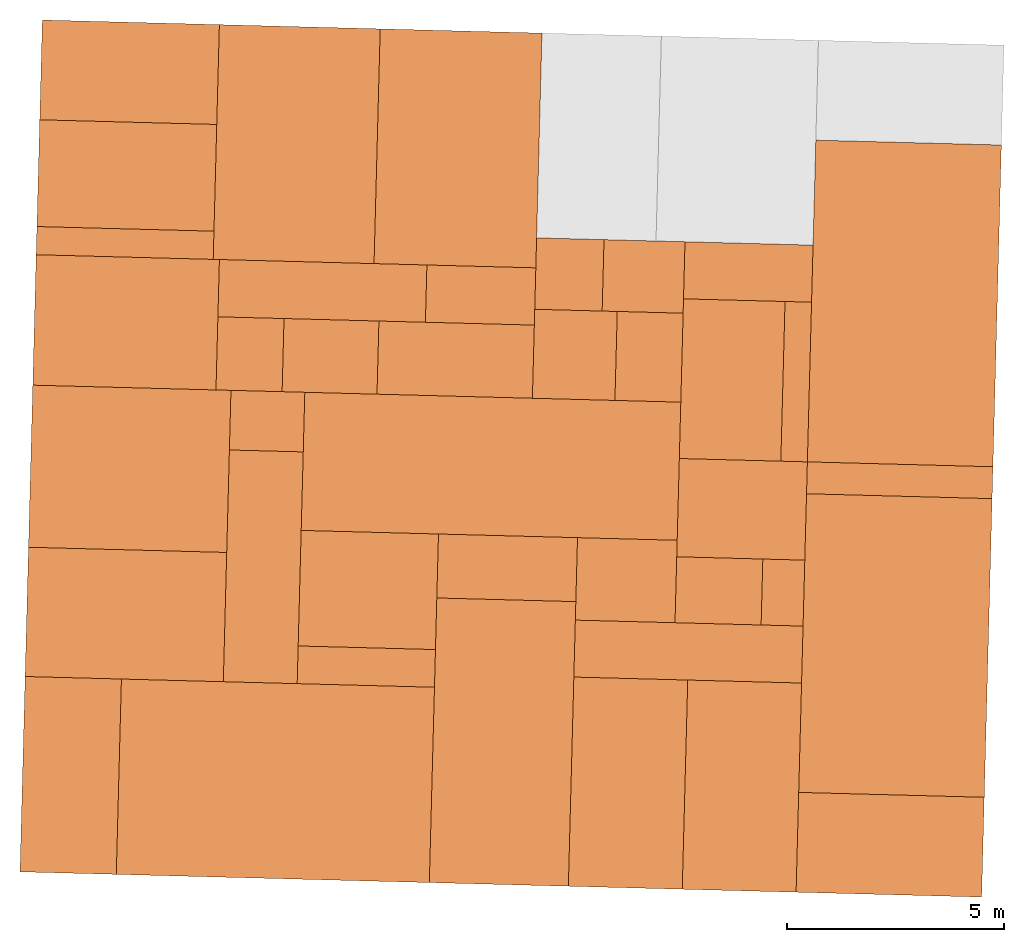
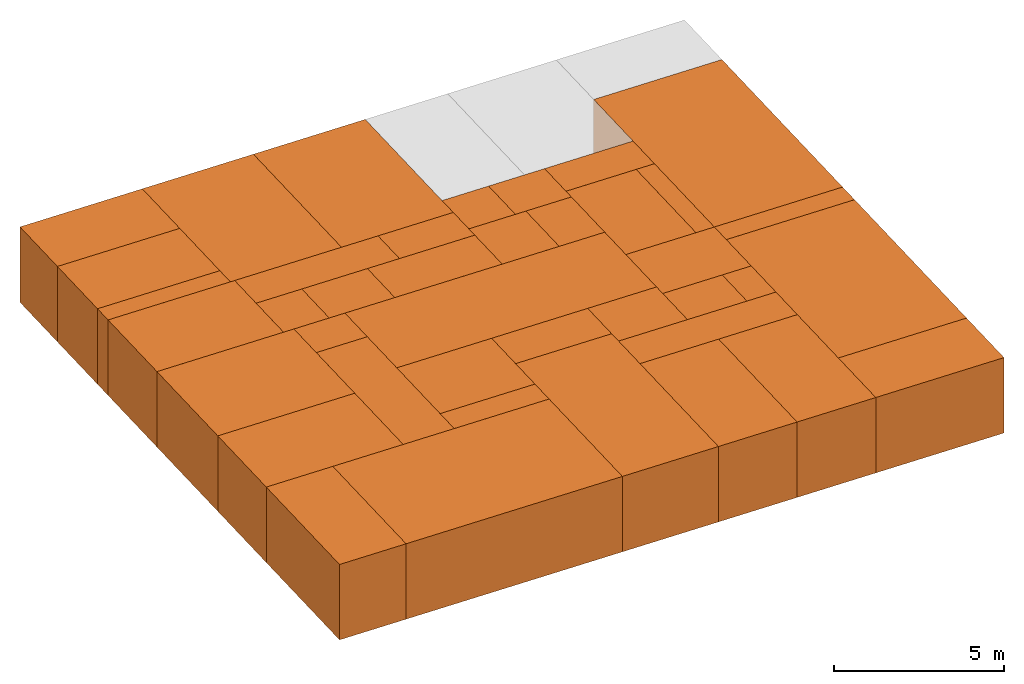
# One storey, part 1 of 2: 40 proxies.
"""IFC2X3 building model written with IfcOpenShell, lengths in metres."""

from ifc_helpers import new_model, entity, si_unit, converted_unit, derived_unit, direction, frame, frame_2d, origin, origin_2d_with_axis, place, context, subcontext, project, spatial, rectangle, extrude, source, transform, mapped, material, type_object, type_shapes, element, save


model = new_model("IFC2X3")

# Units and contexts
model_context = context("Model", 3, precision=1e-05, world=origin(), true_north=direction((-0.999656054706472, -0.0262254130318397)))
body_context = subcontext(model_context, "Body", "Model", "MODEL_VIEW")
ifc_project = project(units=[si_unit("LENGTHUNIT", "METRE"), si_unit("AREAUNIT", "SQUARE_METRE"), si_unit("VOLUMEUNIT", "CUBIC_METRE"), converted_unit("PLANEANGLEUNIT", "DEGREE", entity("IfcRatioMeasure", 0.0174532925199433), si_unit("PLANEANGLEUNIT", "RADIAN"), dimensions=[0, 0, 0, 0, 0, 0, 0]), si_unit("MASSUNIT", "GRAM", prefix="KILO"), derived_unit("MASSDENSITYUNIT", [(si_unit("MASSUNIT", "GRAM", prefix="KILO"), 1), (si_unit("LENGTHUNIT", "METRE"), -3)]), si_unit("TIMEUNIT", "SECOND"), si_unit("FREQUENCYUNIT", "HERTZ"), si_unit("THERMODYNAMICTEMPERATUREUNIT", "DEGREE_CELSIUS"), derived_unit("THERMALTRANSMITTANCEUNIT", [(si_unit("MASSUNIT", "GRAM", prefix="KILO"), 1), (si_unit("THERMODYNAMICTEMPERATUREUNIT", "KELVIN"), -1), (si_unit("TIMEUNIT", "SECOND"), -3)]), derived_unit("VOLUMETRICFLOWRATEUNIT", [(si_unit("LENGTHUNIT", "METRE"), 3), (si_unit("TIMEUNIT", "SECOND"), -1)]), si_unit("ELECTRICCURRENTUNIT", "AMPERE"), si_unit("ELECTRICVOLTAGEUNIT", "VOLT"), si_unit("POWERUNIT", "WATT"), si_unit("FORCEUNIT", "NEWTON", prefix="KILO"), si_unit("ILLUMINANCEUNIT", "LUX"), si_unit("LUMINOUSFLUXUNIT", "LUMEN"), si_unit("LUMINOUSINTENSITYUNIT", "CANDELA"), derived_unit("USERDEFINED", [(si_unit("MASSUNIT", "GRAM", prefix="KILO"), -1), (si_unit("LENGTHUNIT", "METRE"), -2), (si_unit("TIMEUNIT", "SECOND"), 3), (si_unit("LUMINOUSFLUXUNIT", "LUMEN"), 1)]), derived_unit("LINEARVELOCITYUNIT", [(si_unit("LENGTHUNIT", "METRE"), 1), (si_unit("TIMEUNIT", "SECOND"), -1)]), si_unit("PRESSUREUNIT", "PASCAL"), derived_unit("USERDEFINED", [(si_unit("LENGTHUNIT", "METRE"), -2), (si_unit("MASSUNIT", "GRAM", prefix="KILO"), 1), (si_unit("TIMEUNIT", "SECOND"), -2)])], contexts=[model_context])

# Site, building, storey
site_placement = place(None, frame((0.0, 0.0, 0.0), z_axis=(0.0, 0.0, 1.0), x_axis=(-0.0262254130318394, -0.999656054706472, 0.0)))
site = spatial("IfcSite", under=ifc_project, at=site_placement, CompositionType="ELEMENT")
building_placement = place(site_placement, origin())
building = spatial("IfcBuilding", under=site, at=building_placement, CompositionType="ELEMENT")
storey_placement = place(building_placement, frame((0.0, 0.0, 2.7)))
storey = spatial("IfcBuildingStorey", under=building, at=storey_placement, Name="1OG", CompositionType="ELEMENT", Elevation=2.7)

# Proxies
ifc_material_1 = material(Name="010_DiningRoom")
building_element_proxy_type_1 = type_object("IfcBuildingElementProxyType", PredefinedType="NOTDEFINED", material=ifc_material_1)
shared_shape_1 = source(origin(), body_context, "Body", "SweptSolid", [
    extrude(rectangle(XDim=7.41911764705882, YDim=4.27941176470588, at=origin_2d_with_axis()), frame((0.0, 0.0, 0.0), z_axis=(0.0, 0.0, 1.0), x_axis=(-1.0, 0.0, 0.0)), (0.0, 0.0, 1.0), 2.7),
])
type_shapes(building_element_proxy_type_1, [shared_shape_1])
proxy_1_placement = place(storey_placement, frame((1.38045625640379, -30.1803742732614, 0.0)))
element("IfcBuildingElementProxy", 1, at=proxy_1_placement, inside=storey, type_object=building_element_proxy_type_1, material=ifc_material_1, Name="Segment_new:S", context=body_context, shape_type="MappedRepresentation", body=[
    mapped(shared_shape_1, transform((0.0, 0.0, 0.0), scale=1.0)),
])
building_element_proxy_type_2 = type_object("IfcBuildingElementProxyType", PredefinedType="NOTDEFINED", material=ifc_material_1)
shared_shape_2 = source(origin(), body_context, "Body", "SweptSolid", [
    extrude(rectangle(XDim=6.88676470588234, YDim=4.27941176470588, at=origin_2d_with_axis()), frame((0.0, 0.0, 0.0), z_axis=(0.0, 0.0, 1.0), x_axis=(-1.0, 0.0, 0.0)), (0.0, 0.0, 1.0), 2.7),
])
type_shapes(building_element_proxy_type_2, [shared_shape_2])
proxy_2_placement = place(storey_placement, frame((9.26869155052143, -30.1803742732615, 0.0)))
element("IfcBuildingElementProxy", 2, at=proxy_2_placement, inside=storey, type_object=building_element_proxy_type_2, material=ifc_material_1, Name="Segment_new:S", context=body_context, shape_type="MappedRepresentation", body=[
    mapped(shared_shape_2, transform((0.0, 0.0, 0.0), scale=1.0)),
])
ifc_material_2 = material(Name="004_Balcony")
building_element_proxy_type_3 = type_object("IfcBuildingElementProxyType", PredefinedType="NOTDEFINED", material=ifc_material_2)
shared_shape_3 = source(origin(), body_context, "Body", "SweptSolid", [
    extrude(rectangle(XDim=4.27941176470587, YDim=2.30147058823531, at=origin_2d_with_axis()), frame((0.0, 0.0, 0.0), z_axis=(0.0, 0.0, 1.0), x_axis=(0.0, 1.0, 0.0)), (0.0, 0.0, 1.0), 2.7),
])
type_shapes(building_element_proxy_type_3, [shared_shape_3])
proxy_3_placement = place(storey_placement, frame((13.8628091975802, -30.1803742732614, 0.0), z_axis=(0.0, 0.0, 1.0), x_axis=(-1.0, 0.0, 0.0)))
element("IfcBuildingElementProxy", 3, at=proxy_3_placement, inside=storey, type_object=building_element_proxy_type_3, material=ifc_material_2, Name="Segment_new:S", context=body_context, shape_type="MappedRepresentation", body=[
    mapped(shared_shape_3, transform((0.0, 0.0, 0.0), scale=1.0)),
])
ifc_material_3 = material(Name="002_Corridor")
building_element_proxy_type_4 = type_object("IfcBuildingElementProxyType", PredefinedType="NOTDEFINED", material=ifc_material_3)
shared_shape_4 = source(origin(), body_context, "Body", "SweptSolid", [
    extrude(rectangle(XDim=1.31617647058824, YDim=2.9529411764706, at=origin_2d_with_axis()), frame((0.0, 0.0, 0.0), z_axis=(0.0, 0.0, 1.0), x_axis=(-1.0, 0.0, 0.0)), (0.0, 0.0, 1.0), 2.7),
])
type_shapes(building_element_proxy_type_4, [shared_shape_4])
proxy_4_placement = place(storey_placement, frame((0.749573903462615, -33.7965507438497, 0.0)))
element("IfcBuildingElementProxy", 4, at=proxy_4_placement, inside=storey, type_object=building_element_proxy_type_4, material=ifc_material_3, Name="Segment_new:S", context=body_context, shape_type="MappedRepresentation", body=[
    mapped(shared_shape_4, transform((0.0, 0.0, 0.0), scale=1.0)),
])
ifc_material_4 = material(Name="001_Bedroom")
building_element_proxy_type_5 = type_object("IfcBuildingElementProxyType", PredefinedType="NOTDEFINED", material=ifc_material_4)
shared_shape_5 = source(origin(), body_context, "Body", "SweptSolid", [
    extrude(rectangle(XDim=5.41323529411766, YDim=3.73088235294117, at=origin_2d_with_axis()), frame((0.0, 0.0, 0.0), z_axis=(0.0, 0.0, 1.0), x_axis=(-1.0, 0.0, 0.0)), (0.0, 0.0, 1.0), 2.7),
])
type_shapes(building_element_proxy_type_5, [shared_shape_5])
proxy_5_placement = place(storey_placement, frame((-1.9239555083021, -40.560521332085, 0.0)))
element("IfcBuildingElementProxy", 5, at=proxy_5_placement, inside=storey, type_object=building_element_proxy_type_5, material=ifc_material_4, Name="Segment_new:S_Sch", context=body_context, shape_type="MappedRepresentation", body=[
    mapped(shared_shape_5, transform((0.0, 0.0, 0.0), scale=1.0)),
])
building_element_proxy_type_6 = type_object("IfcBuildingElementProxyType", PredefinedType="NOTDEFINED", material=ifc_material_1)
shared_shape_6 = source(origin(), body_context, "Body", "SweptSolid", [
    extrude(rectangle(XDim=5.41323529411766, YDim=3.70882352941175, at=origin_2d_with_axis()), frame((0.0, 0.0, 0.0), z_axis=(0.0, 0.0, 1.0), x_axis=(-1.0, 0.0, 0.0)), (0.0, 0.0, 1.0), 2.7),
])
type_shapes(building_element_proxy_type_6, [shared_shape_6])
proxy_6_placement = place(storey_placement, frame((-1.9239555083021, -44.2803742732614, 0.0)))
element("IfcBuildingElementProxy", 6, at=proxy_6_placement, inside=storey, type_object=building_element_proxy_type_6, material=ifc_material_1, Name="Segment_new:S", context=body_context, shape_type="MappedRepresentation", body=[
    mapped(shared_shape_6, transform((0.0, 0.0, 0.0), scale=1.0)),
])
building_element_proxy_type_7 = type_object("IfcBuildingElementProxyType", PredefinedType="NOTDEFINED", material=ifc_material_2)
shared_shape_7 = source(origin(), body_context, "Body", "SweptSolid", [
    extrude(rectangle(XDim=4.08235294117649, YDim=2.30147058823531, at=origin_2d_with_axis()), frame((0.0, 0.0, 0.0), z_axis=(0.0, 0.0, 1.0), x_axis=(0.0, 1.0, 0.0)), (0.0, 0.0, 1.0), 2.7),
])
type_shapes(building_element_proxy_type_7, [shared_shape_7])
proxy_7_placement = place(storey_placement, frame((-3.47983786124327, -48.1759625085556, 0.0)))
element("IfcBuildingElementProxy", 7, at=proxy_7_placement, inside=storey, type_object=building_element_proxy_type_7, material=ifc_material_2, Name="Segment_new:S", context=body_context, shape_type="MappedRepresentation", body=[
    mapped(shared_shape_7, transform((0.0, 0.0, 0.0), scale=1.0)),
])
ifc_material_5 = material(Name="005_Kitchen")
building_element_proxy_type_8 = type_object("IfcBuildingElementProxyType", PredefinedType="NOTDEFINED", material=ifc_material_5)
shared_shape_8 = source(origin(), body_context, "Body", "SweptSolid", [
    extrude(rectangle(XDim=4.08235294117649, YDim=0.649999999999999, at=origin_2d_with_axis()), frame((0.0, 0.0, 0.0), z_axis=(0.0, 0.0, 1.0), x_axis=(0.0, 1.0, 0.0)), (0.0, 0.0, 1.0), 2.7),
])
type_shapes(building_element_proxy_type_8, [shared_shape_8])
proxy_8_placement = place(storey_placement, frame((0.45766213875673, -48.1759625085556, 0.0)))
element("IfcBuildingElementProxy", 8, at=proxy_8_placement, inside=storey, type_object=building_element_proxy_type_8, material=ifc_material_5, Name="Segment_new:S_Ins", context=body_context, shape_type="MappedRepresentation", body=[
    mapped(shared_shape_8, transform((0.0, 0.0, 0.0), scale=1.0)),
])
building_element_proxy_type_9 = type_object("IfcBuildingElementProxyType", PredefinedType="NOTDEFINED", material=ifc_material_4)
shared_shape_9 = source(origin(), body_context, "Body", "SweptSolid", [
    extrude(rectangle(XDim=4.22500000000002, YDim=3.00735294117647, at=origin_2d_with_axis()), frame((0.0, 0.0, 0.0), z_axis=(0.0, 0.0, 1.0), x_axis=(0.0, 1.0, 0.0)), (0.0, 0.0, 1.0), 2.7),
])
type_shapes(building_element_proxy_type_9, [shared_shape_9])
proxy_9_placement = place(storey_placement, frame((2.28633860934496, -48.1046389791438, 0.0)))
element("IfcBuildingElementProxy", 9, at=proxy_9_placement, inside=storey, type_object=building_element_proxy_type_9, material=ifc_material_4, Name="Segment_new:S_Sch", context=body_context, shape_type="MappedRepresentation", body=[
    mapped(shared_shape_9, transform((0.0, 0.0, 0.0), scale=1.0)),
])
building_element_proxy_type_10 = type_object("IfcBuildingElementProxyType", PredefinedType="NOTDEFINED", material=ifc_material_3)
shared_shape_10 = source(origin(), body_context, "Body", "SweptSolid", [
    extrude(rectangle(XDim=4.78529411764708, YDim=1.32058823529411, at=origin_2d_with_axis()), frame((0.0, 0.0, 0.0), z_axis=(0.0, 0.0, 1.0), x_axis=(0.0, 1.0, 0.0)), (0.0, 0.0, 1.0), 2.7),
])
type_shapes(building_element_proxy_type_10, [shared_shape_10])
proxy_10_placement = place(storey_placement, frame((1.44295625640379, -43.5994919203203, 0.0)))
element("IfcBuildingElementProxy", 10, at=proxy_10_placement, inside=storey, type_object=building_element_proxy_type_10, material=ifc_material_3, Name="Segment_new:S", context=body_context, shape_type="MappedRepresentation", body=[
    mapped(shared_shape_10, transform((0.0, 0.0, 0.0), scale=1.0)),
])
building_element_proxy_type_11 = type_object("IfcBuildingElementProxyType", PredefinedType="NOTDEFINED", material=ifc_material_3)
shared_shape_11 = source(origin(), body_context, "Body", "SweptSolid", [
    extrude(rectangle(XDim=2.18823529411765, YDim=1.68676470588235, at=origin_2d_with_axis()), frame((0.0, 0.0, 0.0), z_axis=(0.0, 0.0, 1.0), x_axis=(0.0, 1.0, 0.0)), (0.0, 0.0, 1.0), 2.7),
])
type_shapes(building_element_proxy_type_11, [shared_shape_11])
proxy_11_placement = place(storey_placement, frame((2.94663272699202, -43.373021332085, 0.0)))
element("IfcBuildingElementProxy", 11, at=proxy_11_placement, inside=storey, type_object=building_element_proxy_type_11, material=ifc_material_3, Name="Segment_new:S", context=body_context, shape_type="MappedRepresentation", body=[
    mapped(shared_shape_11, transform((0.0, 0.0, 0.0), scale=1.0)),
])
ifc_material_6 = material(Name="008_Roof")
building_element_proxy_type_12 = type_object("IfcBuildingElementProxyType", PredefinedType="NOTDEFINED", material=ifc_material_6)
shared_shape_12 = source(origin(), body_context, "Body", "SweptSolid", [
    extrude(rectangle(XDim=1.525, YDim=1.68676470588235, at=origin_2d_with_axis()), frame((0.0, 0.0, 0.0), z_axis=(0.0, 0.0, 1.0), x_axis=(0.0, 1.0, 0.0)), (0.0, 0.0, 1.0), 2.7),
])
type_shapes(building_element_proxy_type_12, [shared_shape_12])
proxy_12_placement = place(storey_placement, frame((2.94663272699202, -45.2296389791438, 0.0)))
element("IfcBuildingElementProxy", 12, at=proxy_12_placement, inside=storey, type_object=building_element_proxy_type_12, material=ifc_material_6, Name="Segment_new:S_Dac", context=body_context, shape_type="MappedRepresentation", body=[
    mapped(shared_shape_12, transform((0.0, 0.0, 0.0), scale=1.0)),
])
ifc_material_7 = material(Name="006_00_Bathroom_Shower")
building_element_proxy_type_13 = type_object("IfcBuildingElementProxyType", PredefinedType="NOTDEFINED", material=ifc_material_7)
shared_shape_13 = source(origin(), body_context, "Body", "SweptSolid", [
    extrude(rectangle(XDim=3.58382352941177, YDim=1.68676470588235, at=origin_2d_with_axis()), frame((0.0, 0.0, 0.0), z_axis=(0.0, 0.0, 1.0), x_axis=(0.0, 1.0, 0.0)), (0.0, 0.0, 1.0), 2.7),
])
type_shapes(building_element_proxy_type_13, [shared_shape_13])
proxy_13_placement = place(storey_placement, frame((2.94663272699203, -40.4869919203203, 0.0)))
element("IfcBuildingElementProxy", 13, at=proxy_13_placement, inside=storey, type_object=building_element_proxy_type_13, material=ifc_material_7, Name="Segment_new:S_Bad", context=body_context, shape_type="MappedRepresentation", body=[
    mapped(shared_shape_13, transform((0.0, 0.0, 0.0), scale=1.0)),
])
building_element_proxy_type_14 = type_object("IfcBuildingElementProxyType", PredefinedType="NOTDEFINED", material=ifc_material_7)
shared_shape_14 = source(origin(), body_context, "Body", "SweptSolid", [
    extrude(rectangle(XDim=2.51176470588236, YDim=1.32058823529412, at=frame_2d((-1.11022302462516e-16, 0.0), x_axis=(1.0, 0.0))), frame((0.0, 0.0, 0.0), z_axis=(0.0, 0.0, 1.0), x_axis=(0.0, 1.0, 0.0)), (0.0, 0.0, 1.0), 2.7),
])
type_shapes(building_element_proxy_type_14, [shared_shape_14])
proxy_14_placement = place(storey_placement, frame((1.4429562564038, -39.9509625085556, 0.0)))
element("IfcBuildingElementProxy", 14, at=proxy_14_placement, inside=storey, type_object=building_element_proxy_type_14, material=ifc_material_7, Name="Segment_new:S_Bad", context=body_context, shape_type="MappedRepresentation", body=[
    mapped(shared_shape_14, transform((0.0, 0.0, 0.0), scale=1.0)),
])
building_element_proxy_type_15 = type_object("IfcBuildingElementProxyType", PredefinedType="NOTDEFINED", material=ifc_material_7)
shared_shape_15 = source(origin(), body_context, "Body", "SweptSolid", [
    extrude(rectangle(XDim=2.34117647058825, YDim=3.68235294117647, at=origin_2d_with_axis()), frame((0.0, 0.0, 0.0), z_axis=(0.0, 0.0, 1.0), x_axis=(0.0, 1.0, 0.0)), (0.0, 0.0, 1.0), 2.7),
])
type_shapes(building_element_proxy_type_15, [shared_shape_15])
proxy_15_placement = place(storey_placement, frame((3.24883860934497, -34.1024330967909, 0.0)))
element("IfcBuildingElementProxy", 15, at=proxy_15_placement, inside=storey, type_object=building_element_proxy_type_15, material=ifc_material_7, Name="Segment_new:S_Bad", context=body_context, shape_type="MappedRepresentation", body=[
    mapped(shared_shape_15, transform((0.0, 0.0, 0.0), scale=1.0)),
])
building_element_proxy_type_16 = type_object("IfcBuildingElementProxyType", PredefinedType="NOTDEFINED", material=ifc_material_5)
shared_shape_16 = source(origin(), body_context, "Body", "SweptSolid", [
    extrude(rectangle(XDim=0.611764705882343, YDim=3.68235294117647, at=origin_2d_with_axis()), frame((0.0, 0.0, 0.0), z_axis=(0.0, 0.0, 1.0), x_axis=(0.0, 1.0, 0.0)), (0.0, 0.0, 1.0), 2.7),
])
type_shapes(building_element_proxy_type_16, [shared_shape_16])
proxy_16_placement = place(storey_placement, frame((3.24883860934497, -32.6259625085556, 0.0)))
element("IfcBuildingElementProxy", 16, at=proxy_16_placement, inside=storey, type_object=building_element_proxy_type_16, material=ifc_material_5, context=body_context, shape_type="MappedRepresentation", body=[
    mapped(shared_shape_16, transform((0.0, 0.0, 0.0), scale=1.0)),
])
building_element_proxy_type_17 = type_object("IfcBuildingElementProxyType", PredefinedType="NOTDEFINED", material=ifc_material_3)
shared_shape_17 = source(origin(), body_context, "Body", "SweptSolid", [
    extrude(rectangle(XDim=1.64705882352941, YDim=1.86764705882353, at=origin_2d_with_axis()), frame((0.0, 0.0, 0.0), z_axis=(0.0, 0.0, 1.0), x_axis=(-1.0, 0.0, 0.0)), (0.0, 0.0, 1.0), 2.7),
])
type_shapes(building_element_proxy_type_17, [shared_shape_17])
proxy_17_placement = place(storey_placement, frame((0.9150150799332, -36.2068448614967, 0.0)))
element("IfcBuildingElementProxy", 17, at=proxy_17_placement, inside=storey, type_object=building_element_proxy_type_17, material=ifc_material_3, Name="Segment_new:S", context=body_context, shape_type="MappedRepresentation", body=[
    mapped(shared_shape_17, transform((0.0, 0.0, 0.0), scale=1.0)),
])
ifc_material_8 = material(Name="003_LivingRoom")
building_element_proxy_type_18 = type_object("IfcBuildingElementProxyType", PredefinedType="NOTDEFINED", material=ifc_material_8)
shared_shape_18 = source(origin(), body_context, "Body", "SweptSolid", [
    extrude(rectangle(XDim=1.64705882352941, YDim=1.55441176470586, at=origin_2d_with_axis()), frame((0.0, 0.0, 0.0), z_axis=(0.0, 0.0, 1.0), x_axis=(-1.0, 0.0, 0.0)), (0.0, 0.0, 1.0), 2.7),
])
type_shapes(building_element_proxy_type_18, [shared_shape_18])
proxy_18_placement = place(storey_placement, frame((0.915015079933198, -37.9178742732614, 0.0)))
element("IfcBuildingElementProxy", 18, at=proxy_18_placement, inside=storey, type_object=building_element_proxy_type_18, material=ifc_material_8, Name="Segment_new:S", context=body_context, shape_type="MappedRepresentation", body=[
    mapped(shared_shape_18, transform((0.0, 0.0, 0.0), scale=1.0)),
])
building_element_proxy_type_19 = type_object("IfcBuildingElementProxyType", PredefinedType="NOTDEFINED", material=ifc_material_8)
shared_shape_19 = source(origin(), body_context, "Body", "SweptSolid", [
    extrude(rectangle(XDim=2.05147058823529, YDim=1.90294117647058, at=origin_2d_with_axis()), frame((0.0, 0.0, 0.0), z_axis=(0.0, 0.0, 1.0), x_axis=(-1.0, 0.0, 0.0)), (0.0, 0.0, 1.0), 2.7),
])
type_shapes(building_element_proxy_type_19, [shared_shape_19])
proxy_19_placement = place(storey_placement, frame((2.76427978581555, -37.7436095673791, 0.0)))
element("IfcBuildingElementProxy", 19, at=proxy_19_placement, inside=storey, type_object=building_element_proxy_type_19, material=ifc_material_8, Name="Segment_new:S", context=body_context, shape_type="MappedRepresentation", body=[
    mapped(shared_shape_19, transform((0.0, 0.0, 0.0), scale=1.0)),
])
building_element_proxy_type_20 = type_object("IfcBuildingElementProxyType", PredefinedType="NOTDEFINED", material=ifc_material_3)
shared_shape_20 = source(origin(), body_context, "Body", "SweptSolid", [
    extrude(rectangle(XDim=2.05147058823529, YDim=1.51911764705881, at=origin_2d_with_axis()), frame((0.0, 0.0, 0.0), z_axis=(0.0, 0.0, 1.0), x_axis=(-1.0, 0.0, 0.0)), (0.0, 0.0, 1.0), 2.7),
])
type_shapes(building_element_proxy_type_20, [shared_shape_20])
proxy_20_placement = place(storey_placement, frame((2.76427978581555, -36.0325801556144, 0.0)))
element("IfcBuildingElementProxy", 20, at=proxy_20_placement, inside=storey, type_object=building_element_proxy_type_20, material=ifc_material_3, Name="Segment_new:S", context=body_context, shape_type="MappedRepresentation", body=[
    mapped(shared_shape_20, transform((0.0, 0.0, 0.0), scale=1.0)),
])
building_element_proxy_type_21 = type_object("IfcBuildingElementProxyType", PredefinedType="NOTDEFINED", material=ifc_material_4)
shared_shape_21 = source(origin(), body_context, "Body", "SweptSolid", [
    extrude(rectangle(XDim=4.82352941176472, YDim=2.62499999999997, at=origin_2d_with_axis()), frame((0.0, 0.0, 0.0), z_axis=(0.0, 0.0, 1.0), x_axis=(-1.0, 0.0, 0.0)), (0.0, 0.0, 1.0), 2.7),
])
type_shapes(building_element_proxy_type_21, [shared_shape_21])
proxy_21_placement = place(storey_placement, frame((12.6017797858156, -33.6325801556144, 0.0)))
element("IfcBuildingElementProxy", 21, at=proxy_21_placement, inside=storey, type_object=building_element_proxy_type_21, material=ifc_material_4, Name="Segment_new:S_Sch", context=body_context, shape_type="MappedRepresentation", body=[
    mapped(shared_shape_21, transform((0.0, 0.0, 0.0), scale=1.0)),
])
building_element_proxy_type_22 = type_object("IfcBuildingElementProxyType", PredefinedType="NOTDEFINED", material=ifc_material_4)
shared_shape_22 = source(origin(), body_context, "Body", "SweptSolid", [
    extrude(rectangle(XDim=4.82352941176472, YDim=2.62647058823531, at=origin_2d_with_axis()), frame((0.0, 0.0, 0.0), z_axis=(0.0, 0.0, 1.0), x_axis=(-1.0, 0.0, 0.0)), (0.0, 0.0, 1.0), 2.7),
])
type_shapes(building_element_proxy_type_22, [shared_shape_22])
proxy_22_placement = place(storey_placement, frame((12.6017797858156, -36.258315449732, 0.0)))
element("IfcBuildingElementProxy", 22, at=proxy_22_placement, inside=storey, type_object=building_element_proxy_type_22, material=ifc_material_4, Name="Segment_new:S_Sch", context=body_context, shape_type="MappedRepresentation", body=[
    mapped(shared_shape_22, transform((0.0, 0.0, 0.0), scale=1.0)),
])
building_element_proxy_type_23 = type_object("IfcBuildingElementProxyType", PredefinedType="NOTDEFINED", material=ifc_material_3)
shared_shape_23 = source(origin(), body_context, "Body", "SweptSolid", [
    extrude(rectangle(XDim=1.31323529411764, YDim=5.25147058823529, at=origin_2d_with_axis()), frame((0.0, 0.0, 0.0), z_axis=(0.0, 0.0, 1.0), x_axis=(-1.0, 0.0, 0.0)), (0.0, 0.0, 1.0), 2.7),
])
type_shapes(building_element_proxy_type_23, [shared_shape_23])
proxy_23_placement = place(storey_placement, frame((9.53339743287437, -34.9458154497321, 0.0)))
element("IfcBuildingElementProxy", 23, at=proxy_23_placement, inside=storey, type_object=building_element_proxy_type_23, material=ifc_material_3, Name="Segment_new:S", context=body_context, shape_type="MappedRepresentation", body=[
    mapped(shared_shape_23, transform((0.0, 0.0, 0.0), scale=1.0)),
])
building_element_proxy_type_24 = type_object("IfcBuildingElementProxyType", PredefinedType="NOTDEFINED", material=ifc_material_3)
shared_shape_24 = source(origin(), body_context, "Body", "SweptSolid", [
    extrude(rectangle(XDim=1.90147058823529, YDim=2.29852941176471, at=origin_2d_with_axis()), frame((0.0, 0.0, 0.0), z_axis=(0.0, 0.0, 1.0), x_axis=(-1.0, 0.0, 0.0)), (0.0, 0.0, 1.0), 2.7),
])
type_shapes(building_element_proxy_type_24, [shared_shape_24])
proxy_24_placement = place(storey_placement, frame((7.9260444916979, -36.4222860379673, 0.0)))
element("IfcBuildingElementProxy", 24, at=proxy_24_placement, inside=storey, type_object=building_element_proxy_type_24, material=ifc_material_3, Name="Segment_new:S", context=body_context, shape_type="MappedRepresentation", body=[
    mapped(shared_shape_24, transform((0.0, 0.0, 0.0), scale=1.0)),
])
building_element_proxy_type_25 = type_object("IfcBuildingElementProxyType", PredefinedType="NOTDEFINED", material=ifc_material_4)
shared_shape_25 = source(origin(), body_context, "Body", "SweptSolid", [
    extrude(rectangle(XDim=6.56323529411764, YDim=3.20588235294116, at=origin_2d_with_axis()), frame((0.0, 0.0, 0.0), z_axis=(0.0, 0.0, 1.0), x_axis=(-1.0, 0.0, 0.0)), (0.0, 0.0, 1.0), 2.7),
])
type_shapes(building_element_proxy_type_25, [shared_shape_25])
proxy_25_placement = place(storey_placement, frame((11.7319268446391, -39.1744919203203, 0.0)))
element("IfcBuildingElementProxy", 25, at=proxy_25_placement, inside=storey, type_object=building_element_proxy_type_25, material=ifc_material_4, Name="Segment_new:S_Sch", context=body_context, shape_type="MappedRepresentation", body=[
    mapped(shared_shape_25, transform((0.0, 0.0, 0.0), scale=1.0)),
])
building_element_proxy_type_26 = type_object("IfcBuildingElementProxyType", PredefinedType="NOTDEFINED", material=ifc_material_7)
shared_shape_26 = source(origin(), body_context, "Body", "SweptSolid", [
    extrude(rectangle(XDim=3.20588235294117, YDim=1.47500000000001, at=origin_2d_with_axis()), frame((0.0, 0.0, 0.0), z_axis=(0.0, 0.0, 1.0), x_axis=(0.0, 1.0, 0.0)), (0.0, 0.0, 1.0), 2.7),
])
type_shapes(building_element_proxy_type_26, [shared_shape_26])
proxy_26_placement = place(storey_placement, frame((7.71280919758026, -39.1744919203203, 0.0)))
element("IfcBuildingElementProxy", 26, at=proxy_26_placement, inside=storey, type_object=building_element_proxy_type_26, material=ifc_material_7, Name="Segment_new:S_Bad", context=body_context, shape_type="MappedRepresentation", body=[
    mapped(shared_shape_26, transform((0.0, 0.0, 0.0), scale=1.0)),
])
building_element_proxy_type_27 = type_object("IfcBuildingElementProxyType", PredefinedType="NOTDEFINED", material=ifc_material_7)
shared_shape_27 = source(origin(), body_context, "Body", "SweptSolid", [
    extrude(rectangle(XDim=2.9529411764706, YDim=2.26617647058823, at=origin_2d_with_axis()), frame((0.0, 0.0, 0.0), z_axis=(0.0, 0.0, 1.0), x_axis=(0.0, 1.0, 0.0)), (0.0, 0.0, 1.0), 2.7),
])
type_shapes(building_element_proxy_type_27, [shared_shape_27])
proxy_27_placement = place(storey_placement, frame((6.22310331522732, -33.7965507438497, 0.0)))
element("IfcBuildingElementProxy", 27, at=proxy_27_placement, inside=storey, type_object=building_element_proxy_type_27, material=ifc_material_7, Name="Segment_new:S_Bad", context=body_context, shape_type="MappedRepresentation", body=[
    mapped(shared_shape_27, transform((0.0, 0.0, 0.0), scale=1.0)),
])
building_element_proxy_type_28 = type_object("IfcBuildingElementProxyType", PredefinedType="NOTDEFINED", material=ifc_material_7)
shared_shape_28 = source(origin(), body_context, "Body", "SweptSolid", [
    extrude(rectangle(XDim=1.98529411764705, YDim=1.52058823529412, at=origin_2d_with_axis()), frame((0.0, 0.0, 0.0), z_axis=(0.0, 0.0, 1.0), x_axis=(0.0, 1.0, 0.0)), (0.0, 0.0, 1.0), 2.7),
])
type_shapes(building_element_proxy_type_28, [shared_shape_28])
proxy_28_placement = place(storey_placement, frame((8.1164856681685, -34.2803742732615, 0.0)))
element("IfcBuildingElementProxy", 28, at=proxy_28_placement, inside=storey, type_object=building_element_proxy_type_28, material=ifc_material_7, Name="Segment_new:S_Bad", context=body_context, shape_type="MappedRepresentation", body=[
    mapped(shared_shape_28, transform((0.0, 0.0, 0.0), scale=1.0)),
])
building_element_proxy_type_29 = type_object("IfcBuildingElementProxyType", PredefinedType="NOTDEFINED", material=ifc_material_6)
shared_shape_29 = source(origin(), body_context, "Body", "SweptSolid", [
    extrude(rectangle(XDim=0.967647058823531, YDim=1.52058823529412, at=frame_2d((0.0, -5.55111512312578e-17), x_axis=(1.0, 0.0))), frame((0.0, 0.0, 0.0), z_axis=(0.0, 0.0, 1.0), x_axis=(0.0, 1.0, 0.0)), (0.0, 0.0, 1.0), 2.7),
])
type_shapes(building_element_proxy_type_29, [shared_shape_29])
proxy_29_placement = place(storey_placement, frame((8.1164856681685, -32.8039036850262, 0.0)))
element("IfcBuildingElementProxy", 29, at=proxy_29_placement, inside=storey, type_object=building_element_proxy_type_29, material=ifc_material_6, Name="Segment_new:S_Dac", context=body_context, shape_type="MappedRepresentation", body=[
    mapped(shared_shape_29, transform((0.0, 0.0, 0.0), scale=1.0)),
])
ifc_material_9 = material(Name="017")
building_element_proxy_type_30 = type_object("IfcBuildingElementProxyType", PredefinedType="NOTDEFINED", material=ifc_material_9)
shared_shape_30 = source(origin(), body_context, "Body", "SweptSolid", [
    extrude(rectangle(XDim=3.18529411764706, YDim=8.67058823529413, at=frame_2d((0.0, -4.44089209850063e-16), x_axis=(1.0, 0.0))), frame((0.0, 0.0, 0.0), z_axis=(0.0, 0.0, 1.0), x_axis=(-1.0, 0.0, 0.0)), (0.0, 0.0, 1.0), 2.7),
])
type_shapes(building_element_proxy_type_30, [shared_shape_30])
proxy_30_placement = place(storey_placement, frame((5.38266213875672, -39.608315449732, 0.0)))
element("IfcBuildingElementProxy", 30, at=proxy_30_placement, inside=storey, type_object=building_element_proxy_type_30, material=ifc_material_9, Name="Segment_new:S_Tre", context=body_context, shape_type="MappedRepresentation", body=[
    mapped(shared_shape_30, transform((0.0, 0.0, 0.0), scale=1.0)),
])
building_element_proxy_type_31 = type_object("IfcBuildingElementProxyType", PredefinedType="NOTDEFINED", material=ifc_material_7)
shared_shape_31 = source(origin(), body_context, "Body", "SweptSolid", [
    extrude(rectangle(XDim=3.16617647058826, YDim=2.66470588235295, at=origin_2d_with_axis()), frame((0.0, 0.0, 0.0), z_axis=(0.0, 0.0, 1.0), x_axis=(0.0, 1.0, 0.0)), (0.0, 0.0, 1.0), 2.7),
])
type_shapes(building_element_proxy_type_31, [shared_shape_31])
proxy_31_placement = place(storey_placement, frame((8.30766213875673, -42.360521332085, 0.0)))
element("IfcBuildingElementProxy", 31, at=proxy_31_placement, inside=storey, type_object=building_element_proxy_type_31, material=ifc_material_7, Name="Segment_new:S_Bad", context=body_context, shape_type="MappedRepresentation", body=[
    mapped(shared_shape_31, transform((0.0, 0.0, 0.0), scale=1.0)),
])
building_element_proxy_type_32 = type_object("IfcBuildingElementProxyType", PredefinedType="NOTDEFINED", material=ifc_material_5)
shared_shape_32 = source(origin(), body_context, "Body", "SweptSolid", [
    extrude(rectangle(XDim=3.16617647058822, YDim=0.869117647058837, at=origin_2d_with_axis()), frame((0.0, 0.0, 0.0), z_axis=(0.0, 0.0, 1.0), x_axis=(0.0, 1.0, 0.0)), (0.0, 0.0, 1.0), 2.7),
])
type_shapes(building_element_proxy_type_32, [shared_shape_32])
proxy_32_placement = place(storey_placement, frame((10.0745739034626, -42.360521332085, 0.0)))
element("IfcBuildingElementProxy", 32, at=proxy_32_placement, inside=storey, type_object=building_element_proxy_type_32, material=ifc_material_5, context=body_context, shape_type="MappedRepresentation", body=[
    mapped(shared_shape_32, transform((0.0, 0.0, 0.0), scale=1.0)),
])
building_element_proxy_type_33 = type_object("IfcBuildingElementProxyType", PredefinedType="NOTDEFINED", material=ifc_material_1)
shared_shape_33 = source(origin(), body_context, "Body", "SweptSolid", [
    extrude(rectangle(XDim=4.50441176470587, YDim=7.2191176470588, at=origin_2d_with_axis()), frame((0.0, 0.0, 0.0), z_axis=(0.0, 0.0, 1.0), x_axis=(-1.0, 0.0, 0.0)), (0.0, 0.0, 1.0), 2.7),
])
type_shapes(building_element_proxy_type_33, [shared_shape_33])
proxy_33_placement = place(storey_placement, frame((12.761338609345, -44.3869919203203, 0.0)))
element("IfcBuildingElementProxy", 33, at=proxy_33_placement, inside=storey, type_object=building_element_proxy_type_33, material=ifc_material_1, Name="Segment_new:S", context=body_context, shape_type="MappedRepresentation", body=[
    mapped(shared_shape_33, transform((0.0, 0.0, 0.0), scale=1.0)),
])
building_element_proxy_type_34 = type_object("IfcBuildingElementProxyType", PredefinedType="NOTDEFINED", material=ifc_material_2)
shared_shape_34 = source(origin(), body_context, "Body", "SweptSolid", [
    extrude(rectangle(XDim=2.22058823529411, YDim=4.50441176470587, at=origin_2d_with_axis()), frame((0.0, 0.0, 0.0), z_axis=(0.0, 0.0, 1.0), x_axis=(0.0, 1.0, 0.0)), (0.0, 0.0, 1.0), 2.7),
])
type_shapes(building_element_proxy_type_34, [shared_shape_34])
proxy_34_placement = place(storey_placement, frame((12.761338609345, -49.1068448614967, 0.0)))
element("IfcBuildingElementProxy", 34, at=proxy_34_placement, inside=storey, type_object=building_element_proxy_type_34, material=ifc_material_2, Name="Segment_new:S", context=body_context, shape_type="MappedRepresentation", body=[
    mapped(shared_shape_34, transform((0.0, 0.0, 0.0), scale=1.0)),
])
building_element_proxy_type_35 = type_object("IfcBuildingElementProxyType", PredefinedType="NOTDEFINED", material=ifc_material_6)
shared_shape_35 = source(origin(), body_context, "Body", "SweptSolid", [
    extrude(rectangle(XDim=1.7029411764706, YDim=1.37500000000002, at=origin_2d_with_axis()), frame((0.0, 0.0, 0.0), z_axis=(0.0, 0.0, 1.0), x_axis=(0.0, 1.0, 0.0)), (0.0, 0.0, 1.0), 2.7),
])
type_shapes(building_element_proxy_type_35, [shared_shape_35])
proxy_35_placement = place(storey_placement, frame((4.47751507993319, -44.7950801556144, 0.0)))
element("IfcBuildingElementProxy", 35, at=proxy_35_placement, inside=storey, type_object=building_element_proxy_type_35, material=ifc_material_6, Name="Segment_new:S_Dac", context=body_context, shape_type="MappedRepresentation", body=[
    mapped(shared_shape_35, transform((0.0, 0.0, 0.0), scale=1.0)),
])
building_element_proxy_type_36 = type_object("IfcBuildingElementProxyType", PredefinedType="NOTDEFINED", material=ifc_material_3)
shared_shape_36 = source(origin(), body_context, "Body", "SweptSolid", [
    extrude(rectangle(XDim=1.7029411764706, YDim=5.34411764705883, at=origin_2d_with_axis()), frame((0.0, 0.0, 0.0), z_axis=(0.0, 0.0, 1.0), x_axis=(0.0, 1.0, 0.0)), (0.0, 0.0, 1.0), 2.7),
])
type_shapes(building_element_proxy_type_36, [shared_shape_36])
proxy_36_placement = place(storey_placement, frame((7.83707390346262, -44.7950801556144, 0.0)))
element("IfcBuildingElementProxy", 36, at=proxy_36_placement, inside=storey, type_object=building_element_proxy_type_36, material=ifc_material_3, Name="Segment_new:S", context=body_context, shape_type="MappedRepresentation", body=[
    mapped(shared_shape_36, transform((0.0, 0.0, 0.0), scale=1.0)),
])
building_element_proxy_type_37 = type_object("IfcBuildingElementProxyType", PredefinedType="NOTDEFINED", material=ifc_material_4)
shared_shape_37 = source(origin(), body_context, "Body", "SweptSolid", [
    extrude(rectangle(XDim=3.73823529411768, YDim=4.57058823529412, at=origin_2d_with_axis()), frame((0.0, 0.0, 0.0), z_axis=(0.0, 0.0, 1.0), x_axis=(-1.0, 0.0, 0.0)), (0.0, 0.0, 1.0), 2.7),
])
type_shapes(building_element_proxy_type_37, [shared_shape_37])
proxy_37_placement = place(storey_placement, frame((5.65913272699202, -47.9318448614968, 0.0)))
element("IfcBuildingElementProxy", 37, at=proxy_37_placement, inside=storey, type_object=building_element_proxy_type_37, material=ifc_material_4, Name="Segment_new:S_Sch", context=body_context, shape_type="MappedRepresentation", body=[
    mapped(shared_shape_37, transform((0.0, 0.0, 0.0), scale=1.0)),
])
building_element_proxy_type_38 = type_object("IfcBuildingElementProxyType", PredefinedType="NOTDEFINED", material=ifc_material_4)
shared_shape_38 = source(origin(), body_context, "Body", "SweptSolid", [
    extrude(rectangle(XDim=2.98088235294117, YDim=4.57058823529412, at=origin_2d_with_axis()), frame((0.0, 0.0, 0.0), z_axis=(0.0, 0.0, 1.0), x_axis=(-1.0, 0.0, 0.0)), (0.0, 0.0, 1.0), 2.7),
])
type_shapes(building_element_proxy_type_38, [shared_shape_38])
proxy_38_placement = place(storey_placement, frame((9.01869155052144, -47.9318448614968, 0.0)))
element("IfcBuildingElementProxy", 38, at=proxy_38_placement, inside=storey, type_object=building_element_proxy_type_38, material=ifc_material_4, Name="Segment_new:S_Sch", context=body_context, shape_type="MappedRepresentation", body=[
    mapped(shared_shape_38, transform((0.0, 0.0, 0.0), scale=1.0)),
])
building_element_proxy_type_39 = type_object("IfcBuildingElementProxyType", PredefinedType="NOTDEFINED", material=ifc_material_1)
shared_shape_39 = source(origin(), body_context, "Body", "SweptSolid", [
    extrude(rectangle(XDim=4.08235294117649, YDim=2.46176470588235, at=origin_2d_with_axis()), frame((0.0, 0.0, 0.0), z_axis=(0.0, 0.0, 1.0), x_axis=(0.0, 1.0, 0.0)), (0.0, 0.0, 1.0), 2.7),
])
type_shapes(building_element_proxy_type_39, [shared_shape_39])
proxy_39_placement = place(storey_placement, frame((-1.09822021418444, -48.1759625085556, 0.0)))
element("IfcBuildingElementProxy", 39, at=proxy_39_placement, inside=storey, type_object=building_element_proxy_type_39, material=ifc_material_1, Name="Segment_new:S", context=body_context, shape_type="MappedRepresentation", body=[
    mapped(shared_shape_39, transform((0.0, 0.0, 0.0), scale=1.0)),
])
building_element_proxy_type_40 = type_object("IfcBuildingElementProxyType", PredefinedType="NOTDEFINED", material=ifc_material_5)
shared_shape_40 = source(origin(), body_context, "Body", "SweptSolid", [
    extrude(rectangle(XDim=4.27941176470588, YDim=0.735294117647064, at=origin_2d_with_axis()), frame((0.0, 0.0, 0.0), z_axis=(0.0, 0.0, 1.0), x_axis=(0.0, 1.0, 0.0)), (0.0, 0.0, 1.0), 2.7),
])
type_shapes(building_element_proxy_type_40, [shared_shape_40])
proxy_40_placement = place(storey_placement, frame((5.45766213875672, -30.1803742732615, 0.0)))
element("IfcBuildingElementProxy", 40, at=proxy_40_placement, inside=storey, type_object=building_element_proxy_type_40, material=ifc_material_5, context=body_context, shape_type="MappedRepresentation", body=[
    mapped(shared_shape_40, transform((0.0, 0.0, 0.0), scale=1.0)),
])

save(model, "model.ifc")
